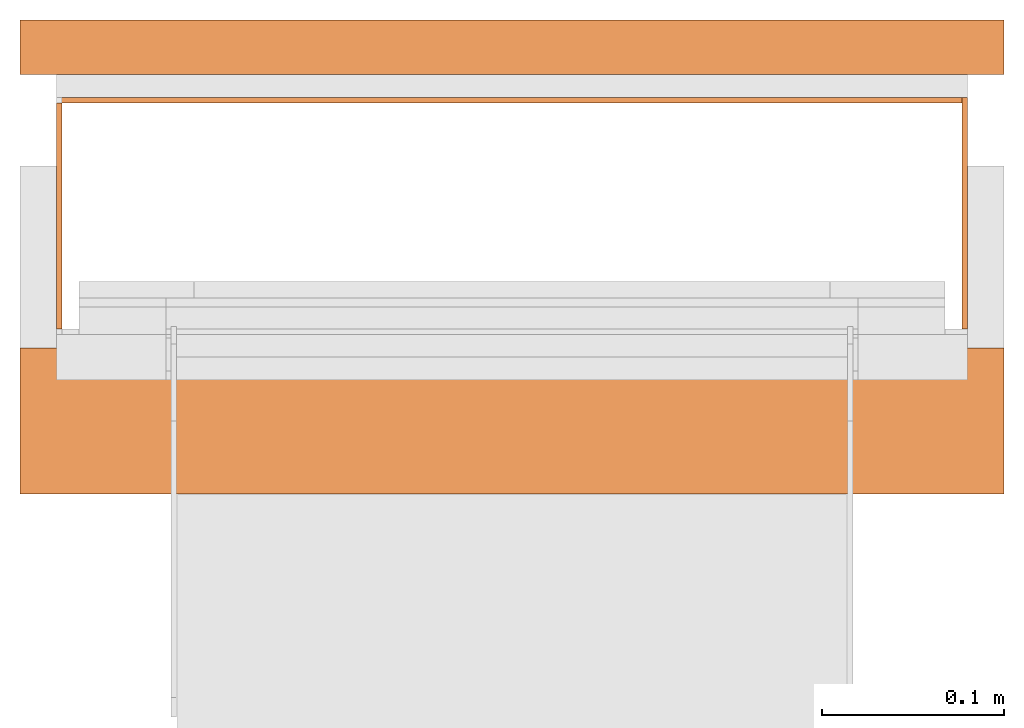
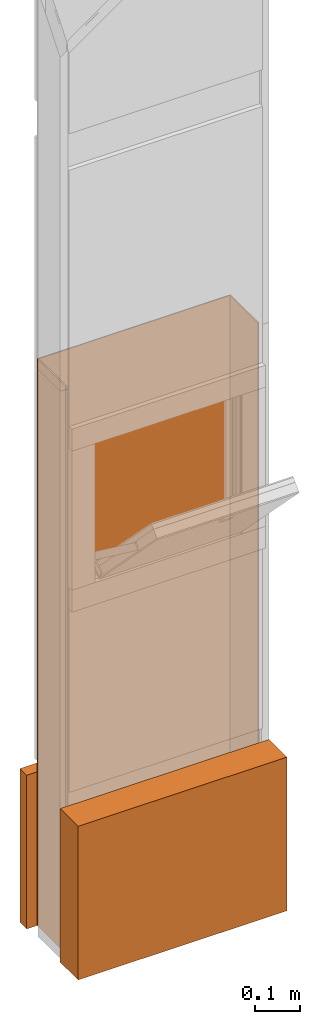
# One storey, part 3 of 3: 4 proxies.
"""IFC2X3 building model written with IfcOpenShell, lengths in metres."""

from ifc_helpers import new_model, entity, si_unit, converted_unit, derived_unit, money_unit, direction, frame, origin_with_axes, place, context, subcontext, project, spatial, polyline, outline, extrude, boolean, faceted_brep, material, type_object, element, save


model = new_model("IFC2X3")

# Units and contexts
model_context = context("Model", 3, precision=1e-05, world=origin_with_axes(), true_north=direction((0.0, 1.0)))
plan_context = context("Plan", 3, precision=1e-05, world=origin_with_axes(), true_north=direction((0.0, 1.0)))
body_context = subcontext(model_context, "Body", "Model", "MODEL_VIEW")
ifc_project = project(units=[si_unit("LENGTHUNIT", "METRE"), si_unit("AREAUNIT", "SQUARE_METRE"), si_unit("VOLUMEUNIT", "CUBIC_METRE"), converted_unit("PLANEANGLEUNIT", "DEGREE", entity("IfcPlaneAngleMeasure", 0.0174532925199), si_unit("PLANEANGLEUNIT", "RADIAN"), dimensions=[0, 0, 0, 0, 0, 0, 0]), si_unit("SOLIDANGLEUNIT", "STERADIAN"), money_unit("CHF"), converted_unit("TIMEUNIT", "Year", entity("IfcTimeMeasure", 31556926.0), si_unit("TIMEUNIT", "SECOND"), dimensions=[0, 0, 1, 0, 0, 0, 0]), si_unit("MASSUNIT", "GRAM", prefix="KILO"), si_unit("THERMODYNAMICTEMPERATUREUNIT", "DEGREE_CELSIUS"), si_unit("LUMINOUSINTENSITYUNIT", "LUMEN"), si_unit("ENERGYUNIT", "JOULE", prefix="MEGA"), derived_unit("THERMALCONDUCTANCEUNIT", [(si_unit("POWERUNIT", "WATT"), 1), (si_unit("LENGTHUNIT", "METRE"), -1), (si_unit("THERMODYNAMICTEMPERATUREUNIT", "KELVIN"), -1)]), derived_unit("SPECIFICHEATCAPACITYUNIT", [(si_unit("ENERGYUNIT", "JOULE"), 1), (si_unit("MASSUNIT", "GRAM", prefix="KILO"), -1), (si_unit("THERMODYNAMICTEMPERATUREUNIT", "KELVIN"), -1)]), derived_unit("MASSDENSITYUNIT", [(si_unit("MASSUNIT", "GRAM", prefix="KILO"), 1), (si_unit("VOLUMEUNIT", "CUBIC_METRE"), -1)])], contexts=[model_context, plan_context])

# Site, building, storey
site_placement = place(None, origin_with_axes())
site = spatial("IfcSite", under=ifc_project, at=site_placement, CompositionType="ELEMENT")
building_placement = place(site_placement, origin_with_axes())
building = spatial("IfcBuilding", under=site, at=building_placement, CompositionType="ELEMENT")
storey_placement = place(building_placement, frame((0.0, 0.0, 2.96), z_axis=(0.0, 0.0, 1.0), x_axis=(1.0, 0.0, 0.0)))
storey = spatial("IfcBuildingStorey", under=building, at=storey_placement, Name="OG01", CompositionType="ELEMENT", Elevation=2.96)

# Proxies
ifc_material_1 = material(Name="Metall, Stahl")
building_element_proxy_type_1 = type_object("IfcBuildingElementProxyType", Name="Metall, Stahl 3", PredefinedType="NOTDEFINED")
proxy_1_placement = place(storey_placement, frame((2.05655524907, -8.22743070606, -0.4), z_axis=(0.0, 0.0, 1.0), x_axis=(0.0, 1.0, 0.0)))
element("IfcBuildingElementProxy", 1, at=proxy_1_placement, inside=storey, type_object=building_element_proxy_type_1, material=ifc_material_1, Name="Wand-007", context=body_context, shape_type="CSG", body=[
    boolean("DIFFERENCE", extrude(outline(polyline([(0.0, 0.0), (0.13, 0.0), (0.13, 0.003), (0.0, 0.003), (0.0, 0.0)])), origin_with_axes(), (0.0, 0.0, 1.0), 1.55), faceted_brep([(0.003, 0.0, 0.0), (0.003, 0.0, 1.55), (0.0, 0.0, 1.55), (0.0, 0.0, 0.0), (0.003, 0.003, 1.55), (0.003, 0.003, 0.0), (0.0, 0.003, 1.55), (0.0, 0.003, 0.0)], [[[0, 1, 2, 3]], [[4, 1, 0, 5]], [[1, 4, 6, 2]], [[6, 7, 3, 2]], [[5, 0, 3, 7]], [[4, 5, 7, 6]]])),
])
proxy_2_placement = place(storey_placement, frame((2.05655524907, -8.09743070606, -0.4), z_axis=(0.0, 0.0, 1.0), x_axis=(-1.0, 0.0, 0.0)))
element("IfcBuildingElementProxy", 2, at=proxy_2_placement, inside=storey, type_object=building_element_proxy_type_1, material=ifc_material_1, Name="Wand-008", context=body_context, shape_type="CSG", body=[
    boolean("DIFFERENCE", extrude(outline(polyline([(0.0, 0.0), (0.5, 0.0), (0.5, 0.003), (0.0, 0.003), (0.0, 0.0)])), origin_with_axes(), (0.0, 0.0, 1.0), 1.55), faceted_brep([(0.003, 0.0, 0.0), (0.003, 0.0, 1.55), (0.0, 0.0, 1.55), (0.0, 0.0, 0.0), (0.003, 0.003, 1.55), (0.003, 0.003, 0.0), (0.0, 0.003, 1.55), (0.0, 0.003, 0.0)], [[[0, 1, 2, 3]], [[4, 1, 0, 5]], [[1, 4, 6, 2]], [[6, 7, 3, 2]], [[5, 0, 3, 7]], [[4, 5, 7, 6]]])),
])
proxy_3_placement = place(storey_placement, frame((1.55655524907, -8.22743070606, -0.4), z_axis=(0.0, 0.0, 1.0), x_axis=(0.0, 1.0, 0.0)))
element("IfcBuildingElementProxy", 3, at=proxy_3_placement, inside=storey, type_object=building_element_proxy_type_1, material=ifc_material_1, Name="Wand-007", context=body_context, shape_type="CSG", body=[
    boolean("DIFFERENCE", boolean("DIFFERENCE", extrude(outline(polyline([(0.0, -0.003), (0.13, -0.003), (0.13, 0.0), (0.0, 0.0), (0.0, -0.003)])), origin_with_axes(), (0.0, 0.0, 1.0), 1.55), faceted_brep([(0.003, -0.003, 0.0), (0.003, -0.003, 1.55), (0.0, -0.003, 1.55), (0.0, -0.003, 0.0), (0.003, 0.0, 1.55), (0.003, 0.0, 0.0), (0.0, 0.0, 1.55), (0.0, 0.0, 0.0)], [[[0, 1, 2, 3]], [[4, 1, 0, 5]], [[1, 4, 6, 2]], [[6, 7, 3, 2]], [[5, 0, 3, 7]], [[4, 5, 7, 6]]])), faceted_brep([(0.127, 0.0, 1.55), (0.127, -0.003, 1.55), (0.13, -0.003, 1.55), (0.13, 0.0, 1.55), (0.127, -0.003, 0.0), (0.127, 0.0, 0.0), (0.13, -0.003, 0.0), (0.13, 0.0, 0.0)], [[[0, 1, 2, 3]], [[4, 1, 0, 5]], [[1, 4, 6, 2]], [[2, 6, 7, 3]], [[5, 0, 3, 7]], [[4, 5, 7, 6]]])),
])
ifc_material_2 = material(Name="Luft, horizontal")
building_element_proxy_type_2 = type_object("IfcBuildingElementProxyType", Name="Luft, horizontal 420", PredefinedType="NOTDEFINED")
proxy_4_placement = place(storey_placement, frame((1.53655524907, -8.31493070606, 0.01), z_axis=(0.0, 0.0, 1.0), x_axis=(1.0, 0.0, 0.0)))
element("IfcBuildingElementProxy", 4, at=proxy_4_placement, inside=storey, type_object=building_element_proxy_type_2, material=ifc_material_2, Name="Decke-007", context=body_context, shape_type="CSG", body=[
    boolean("DIFFERENCE", extrude(outline(polyline([(0.0, 0.0), (0.54, 0.0), (0.54, 0.26), (0.0, 0.26), (0.0, 0.0)])), frame((0.0, 0.0, -0.42), z_axis=(0.0, 0.0, 1.0), x_axis=(1.0, 0.0, 0.0)), (0.0, 0.0, 1.0), 0.42), faceted_brep([(0.54, 0.23, -0.42), (0.54, 0.23, 0.0), (0.54, 0.08, 0.0), (0.54, 0.08, -0.42), (0.0, 0.23, 0.0), (0.0, 0.23, -0.42), (0.0, 0.08, 0.0), (0.0, 0.08, -0.42)], [[[0, 1, 2, 3]], [[4, 1, 0, 5]], [[1, 4, 6, 2]], [[3, 2, 6, 7]], [[5, 0, 3, 7]], [[4, 5, 7, 6]]])),
])

save(model, "model.ifc")
